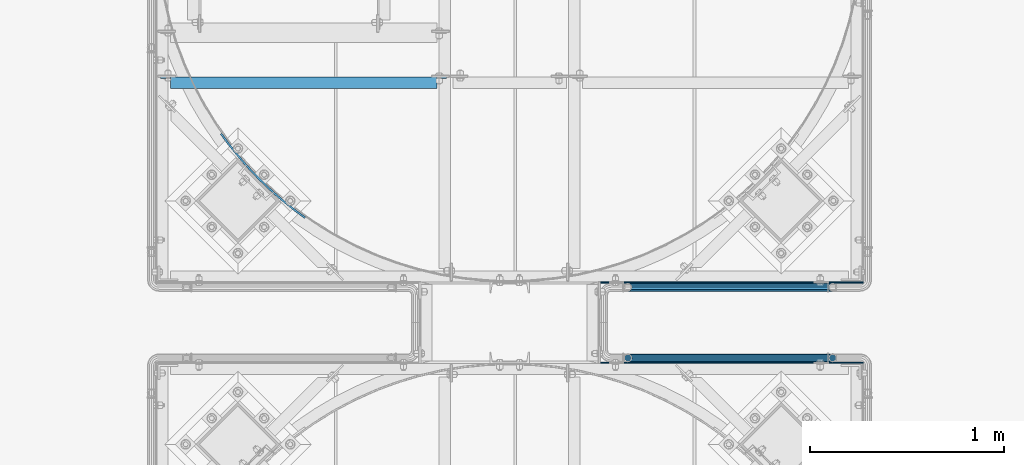
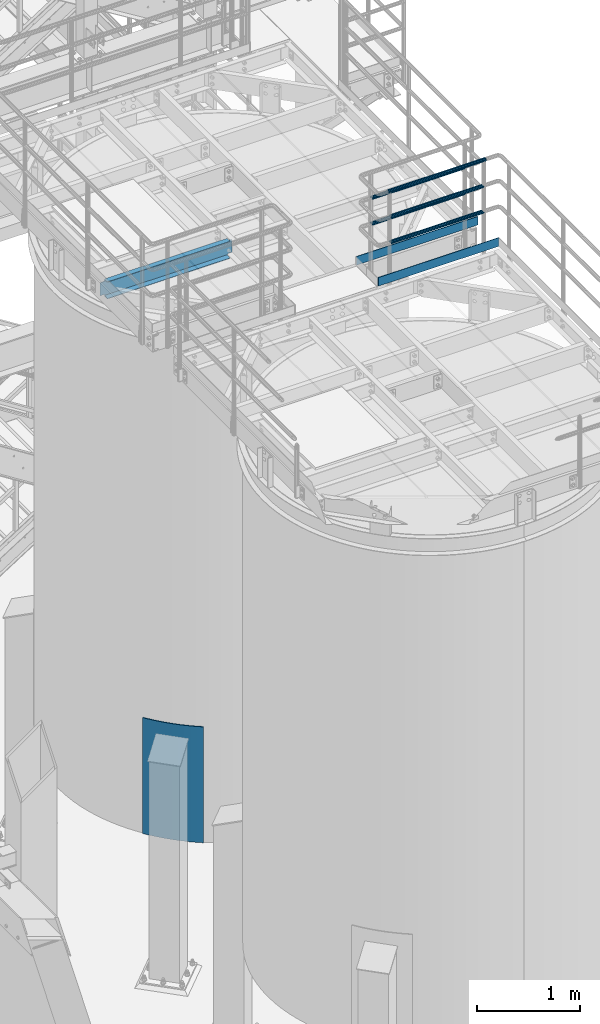
# One storey, part 927 of 1876: 9 beams, 4 elements without a shape of their own.
"""IFC2X3 building model written with IfcOpenShell, lengths in millimetres."""

from ifc_helpers import new_model, si_unit, frame, origin_with_axes, place, context, subcontext, project, spatial, faceted_brep, material, type_object, element, aggregate, save


model = new_model("IFC2X3")

# Units and contexts
model_context = context("Model", 3, precision=1e-05, world=origin_with_axes())
body_context = subcontext(model_context, "Body", "Model", "MODEL_VIEW")
ifc_project = project(units=[si_unit("LENGTHUNIT", "METRE", prefix="MILLI"), si_unit("AREAUNIT", "SQUARE_METRE"), si_unit("VOLUMEUNIT", "CUBIC_METRE"), si_unit("MASSUNIT", "GRAM", prefix="KILO"), si_unit("TIMEUNIT", "SECOND"), si_unit("PLANEANGLEUNIT", "RADIAN"), si_unit("SOLIDANGLEUNIT", "STERADIAN"), si_unit("THERMODYNAMICTEMPERATUREUNIT", "DEGREE_CELSIUS"), si_unit("LUMINOUSINTENSITYUNIT", "LUMEN")], contexts=[model_context])

# Site, building, storey
site_placement = place(None, origin_with_axes())
site = spatial("IfcSite", under=ifc_project, at=site_placement, CompositionType="ELEMENT")
building_placement = place(site_placement, origin_with_axes())
building = spatial("IfcBuilding", under=site, at=building_placement, Name="Undefined", CompositionType="ELEMENT")
storey_placement = place(building_placement, origin_with_axes())
storey = spatial("IfcBuildingStorey", under=building, at=storey_placement, Name="Undefined", CompositionType="ELEMENT", Elevation=0.0)

# Assembly, beams
assembly_1_placement = place(storey_placement, origin_with_axes())
assembly_1 = element("IfcElementAssembly", 1, at=assembly_1_placement, inside=storey, Name="HANDRAIL", AssemblyPlace="NOTDEFINED", PredefinedType="RIGID_FRAME")
ifc_material_1 = material()
beam_type_1 = type_object("IfcBeamType", Name="PIPE1-1/4STD", PredefinedType="NOTDEFINED")
beam_1_placement = place(assembly_1_placement, frame((6845.30143150122, -11745.4324531237, 8480.425), z_axis=(0.0, 0.0, 1.0), x_axis=(-1.0, 0.0, 0.0)))
beam_1 = element("IfcBeam", 2, at=beam_1_placement, type_object=beam_type_1, material=ifc_material_1, Name="RAIL", ObjectType="PIPE1-1/4STD", context=body_context, shape_type="Brep", body=[
    faceted_brep([(1035.84245243742, -10.5409999999993, 18.2575475625836), (1035.84245243742, -10.5409999999993, 13.3999612267253), (1035.36603877327, -8.76300000000083, 15.1779612267255), (1033.018, 0.0, 17.5259999999998), (1033.018, 0.0, 21.0820000000003), (1035.36603877327, 8.76300000000083, 15.1779612267255), (1035.84245243742, 10.5409999999993, 13.3999612267253), (1035.84245243742, 10.5409999999993, 18.2575475625836), (1054.1, 21.0820000000003, 0.0), (1043.559, 18.2575475625836, 10.5409999999993), (1043.559, 18.2575475625836, -10.5409999999993), (1040.47941366414, 15.1779612267255, 8.76300000000083), (1042.82745243742, 17.5259999999998, 0.0), (1040.47941366414, 15.1779612267255, -8.76300000000083), (1035.84245243742, 10.5409999999993, -13.3999612267253), (1035.84245243742, 10.5409999999993, -18.2575475625836), (1035.36603877327, 8.76300000000083, -15.1779612267255), (1033.018, 0.0, -17.5259999999998), (1033.018, 0.0, -21.0820000000003), (1035.84245243742, -10.5409999999993, -13.3999612267253), (1035.84245243742, -10.5409999999993, -18.2575475625836), (1035.36603877327, -8.76300000000083, -15.1779612267255), (1054.1, -21.0820000000003, 0.0), (1043.559, -18.2575475625836, -10.5409999999993), (1043.559, -18.2575475625836, 10.5409999999993), (1040.47941366414, -15.1779612267255, -8.76300000000083), (1042.82745243742, -17.5259999999998, 0.0), (1040.47941366414, -15.1779612267255, 8.76300000000083), (10.5409999957128, -18.2575475672238, -10.5409999999993), (18.2575475625817, -10.5410000000011, -18.2575475625836), (9.09494701772928e-13, 21.0820000000003, 0.0), (10.5409999957128, 18.2575475579433, -10.5409999999993), (10.5409999999983, 18.2575475625836, 10.5410000000011), (18.2575475625817, 10.5409999999993, 18.2575475625836), (21.0819999999985, 1.81898940354586e-12, 21.0820000000003), (18.2575475625817, 10.5409999999993, -18.2575475625836), (21.0819999999985, 0.0, -21.0819999999985), (21.0819999999985, 0.0, -17.5259999999998), (18.2575475625817, -10.5409999999974, -13.3999612267271), (18.7339612267233, -8.76300000000083, -15.1779612267255), (18.7339612267251, 8.76299999999901, -15.1779612267255), (18.2575475625817, 10.5410000000011, -13.3999612267235), (13.6205863358573, 15.1779612267255, -8.76299999999901), (11.2725475625839, 17.5259999999998, 0.0), (13.6205863358573, 15.1779612267255, 8.76300000000083), (18.2575475625817, 10.5410000000011, 13.3999612267253), (18.7339612267251, 8.76299999999901, 15.1779612267273), (21.0819999999985, 1.81898940354586e-12, 17.5259999999998), (18.7339612267233, -8.76300000000083, 15.1779612267273), (18.2575475625817, -10.5409999999974, 13.3999612267289), (18.2575475625817, -10.5410000000011, 18.2575475625836), (10.5409999999983, -18.2575475625836, 10.5410000000011), (9.09494701772928e-13, -21.0820000000003, 0.0), (13.6205863358537, -15.1779612267255, 8.76300000000083), (11.2725475625793, -17.5259999999998, 0.0), (13.6205863358537, -15.1779612267255, -8.76299999999901)], [[[0, 1, 2, 3, 4]], [[4, 3, 5, 6, 7]], [[8, 9, 10]], [[7, 6, 11, 12, 13, 14, 15, 10, 9]], [[16, 17, 18, 15, 14]], [[19, 20, 18, 17, 21]], [[22, 23, 24]], [[24, 23, 20, 19, 25, 26, 27, 1, 0]], [[28, 29, 20, 23]], [[30, 31, 32]], [[33, 34, 4, 7]], [[32, 33, 7, 9]], [[30, 32, 9, 8]], [[31, 30, 8, 10]], [[35, 31, 10, 15]], [[36, 35, 15, 18]], [[29, 36, 18, 20]], [[37, 36, 29, 38, 39]], [[40, 41, 35, 36, 37]], [[32, 31, 35, 41, 42, 43, 44, 45, 33]], [[33, 45, 46, 47, 34]], [[34, 47, 48, 49, 50]], [[34, 50, 0, 4]], [[50, 51, 24, 0]], [[51, 52, 22, 24]], [[52, 28, 23, 22]], [[51, 28, 52]], [[50, 49, 53, 54, 55, 38, 29, 28, 51]], [[55, 54, 26, 25]], [[21, 39, 38, 55, 25, 19]], [[37, 39, 21, 17]], [[40, 37, 17, 16]], [[42, 41, 40, 16, 14, 13]], [[43, 42, 13, 12]], [[44, 43, 12, 11]], [[5, 46, 45, 44, 11, 6]], [[47, 46, 5, 3]], [[48, 47, 3, 2]], [[53, 49, 48, 2, 1, 27]], [[54, 53, 27, 26]]]),
])
beam_2_placement = place(assembly_1_placement, frame((5791.20143150122, -11745.4324531238, 8785.225), z_axis=(0.0, 0.0, -1.0), x_axis=(1.0, 0.0, 0.0)))
beam_2 = element("IfcBeam", 3, at=beam_2_placement, type_object=beam_type_1, material=ifc_material_1, Name="RAIL", ObjectType="PIPE1-1/4STD", context=body_context, shape_type="Brep", body=[
    faceted_brep([(9.09494701772928e-13, 21.0820000000003, 0.0), (10.5409999957128, 18.2575475579433, -10.5409999999993), (10.5409999999983, 18.2575475625836, 10.5410000000011), (10.5409999999983, -18.2575475625836, 10.5410000000011), (10.5409999957128, -18.2575475672238, -10.5409999999993), (9.09494701772928e-13, -21.0820000000003, 0.0), (18.2575475625817, -10.5410000000011, 18.2575475625836), (18.2575475625817, -10.5409999999974, 13.3999612267289), (13.6205863358537, -15.1779612267255, 8.76300000000083), (11.2725475625793, -17.5259999999998, 0.0), (13.6205863358537, -15.1779612267255, -8.76299999999901), (18.2575475625817, -10.5409999999974, -13.3999612267271), (18.2575475625817, -10.5410000000011, -18.2575475625836), (21.0819999999985, 0.0, -17.5259999999998), (21.0819999999985, 0.0, -21.0819999999985), (18.7339612267233, -8.76300000000083, -15.1779612267255), (18.7339612267251, 8.76299999999901, -15.1779612267255), (18.2575475625817, 10.5410000000011, -13.3999612267235), (18.2575475625817, 10.5409999999993, -18.2575475625836), (13.6205863358573, 15.1779612267255, -8.76299999999901), (11.2725475625839, 17.5259999999998, 0.0), (13.6205863358573, 15.1779612267255, 8.76300000000083), (18.2575475625817, 10.5410000000011, 13.3999612267253), (18.2575475625817, 10.5409999999993, 18.2575475625836), (18.7339612267251, 8.76299999999901, 15.1779612267273), (21.0819999999985, 1.81898940354586e-12, 17.5259999999998), (21.0819999999985, 1.81898940354586e-12, 21.0820000000003), (18.7339612267233, -8.76300000000083, 15.1779612267273), (1054.1, 21.0820000000003, 0.0), (1043.559, 18.2575475625836, -10.5409999999993), (1035.84245243742, 10.5409999999993, -18.2575475625836), (1054.1, -21.0820000000003, 0.0), (1043.559, -18.2575475625836, -10.5409999999993), (1043.559, -18.2575475625836, 10.5409999999993), (1035.84245243742, -10.5409999999993, 18.2575475625836), (1035.84245243742, -10.5409999999993, -18.2575475625836), (1033.018, 0.0, -21.0820000000003), (1035.36603877327, 8.76300000000083, -15.1779612267255), (1033.018, 0.0, -17.5259999999998), (1035.84245243742, 10.5409999999993, -13.3999612267253), (1035.84245243742, -10.5409999999993, -13.3999612267253), (1035.36603877327, -8.76300000000083, -15.1779612267255), (1040.47941366414, -15.1779612267255, -8.76300000000083), (1042.82745243742, -17.5259999999998, 0.0), (1040.47941366414, -15.1779612267255, 8.76300000000083), (1035.84245243742, -10.5409999999993, 13.3999612267253), (1035.36603877327, -8.76300000000083, 15.1779612267255), (1033.018, 0.0, 17.5259999999998), (1033.018, 0.0, 21.0820000000003), (1035.84245243742, 10.5409999999993, 18.2575475625836), (1043.559, 18.2575475625836, 10.5409999999993), (1035.84245243742, 10.5409999999993, 13.3999612267253), (1040.47941366414, 15.1779612267255, 8.76300000000083), (1042.82745243742, 17.5259999999998, 0.0), (1040.47941366414, 15.1779612267255, -8.76300000000083), (1035.36603877327, 8.76300000000083, 15.1779612267255)], [[[0, 1, 2]], [[3, 4, 5]], [[6, 7, 8, 9, 10, 11, 12, 4, 3]], [[13, 14, 12, 11, 15]], [[16, 17, 18, 14, 13]], [[2, 1, 18, 17, 19, 20, 21, 22, 23]], [[23, 22, 24, 25, 26]], [[26, 25, 27, 7, 6]], [[1, 0, 28, 29]], [[18, 1, 29, 30]], [[31, 32, 33]], [[6, 3, 33, 34]], [[3, 5, 31, 33]], [[5, 4, 32, 31]], [[4, 12, 35, 32]], [[12, 14, 36, 35]], [[14, 18, 30, 36]], [[37, 38, 36, 30, 39]], [[40, 35, 36, 38, 41]], [[33, 32, 35, 40, 42, 43, 44, 45, 34]], [[34, 45, 46, 47, 48]], [[26, 6, 34, 48]], [[2, 23, 49, 50]], [[23, 26, 48, 49]], [[0, 2, 50, 28]], [[28, 50, 29]], [[49, 51, 52, 53, 54, 39, 30, 29, 50]], [[48, 47, 55, 51, 49]], [[25, 24, 55, 47]], [[55, 24, 22, 21, 52, 51]], [[21, 20, 53, 52]], [[20, 19, 54, 53]], [[19, 17, 16, 37, 39, 54]], [[16, 13, 38, 37]], [[13, 15, 41, 38]], [[41, 15, 11, 10, 42, 40]], [[10, 9, 43, 42]], [[9, 8, 44, 43]], [[8, 7, 27, 46, 45, 44]], [[27, 25, 47, 46]]]),
])
beam_3_placement = place(assembly_1_placement, frame((5770.11943150122, -11745.4324531238, 9090.025), z_axis=(0.0, 0.0, -1.0), x_axis=(1.0, 0.0, 0.0)))
beam_3 = element("IfcBeam", 4, at=beam_3_placement, type_object=beam_type_1, material=ifc_material_1, Name="HANDRAIL", ObjectType="PIPE1-1/4STD", context=body_context, shape_type="Brep", body=[
    faceted_brep([(0.0, -17.5259999999998, 0.0), (0.0, -15.1779612267264, 8.76300000000083), (1096.264, -15.1779612267255, 8.76300000000083), (1096.264, -17.5259999999998, 0.0), (0.0, -8.76299999999992, 15.1779612267255), (1096.264, -8.76300000000083, 15.1779612267255), (0.0, 0.0, 17.5259999999998), (1096.264, 0.0, 17.5259999999998), (0.0, 8.76299999999992, 15.1779612267255), (1096.264, 8.76300000000083, 15.1779612267255), (0.0, 15.1779612267264, 8.76300000000083), (1096.264, 15.1779612267255, 8.76300000000083), (0.0, 17.5259999999998, 0.0), (1096.264, 17.5259999999998, 0.0), (0.0, 15.1779612267264, -8.76300000000083), (1096.264, 15.1779612267255, -8.76300000000083), (0.0, 8.76299999999992, -15.1779612267255), (1096.264, 8.76300000000083, -15.1779612267255), (0.0, 0.0, -17.5259999999998), (1096.264, 0.0, -17.5259999999998), (0.0, -8.76299999999992, -15.1779612267255), (1096.264, -8.76300000000083, -15.1779612267255), (0.0, -15.1779612267264, -8.76300000000083), (1096.264, -15.1779612267255, -8.76300000000083), (9.09494701772928e-13, -21.0820000000003, 0.0), (0.0, -18.2575475625836, -10.5409999999993), (1096.264, -18.2575475625836, -10.5409999999993), (1096.264, -21.0820000000003, 0.0), (0.0, -10.5410000000002, -18.2575475625836), (1096.264, -10.5409999999993, -18.2575475625836), (-4.28826751885936e-09, 0.0, -21.0820000000003), (1096.264, 0.0, -21.0820000000003), (0.0, 10.5410000000002, -18.2575475625836), (1096.264, 10.5409999999993, -18.2575475625836), (0.0, 18.2575475625836, -10.5409999999993), (1096.264, 18.2575475625836, -10.5409999999993), (9.09494701772928e-13, 21.0820000000003, 0.0), (1096.264, 21.0820000000003, 0.0), (0.0, 18.2575475625836, 10.5409999999993), (1096.264, 18.2575475625836, 10.5409999999993), (0.0, 10.5410000000002, 18.2575475625836), (1096.264, 10.5409999999993, 18.2575475625836), (0.0, 0.0, 21.0820000000003), (1096.264, 0.0, 21.0820000000003), (0.0, -10.5410000000002, 18.2575475625836), (1096.264, -10.5409999999993, 18.2575475625836), (0.0, -18.2575475625836, 10.5409999999993), (1096.264, -18.2575475625836, 10.5409999999993)], [[[0, 1, 2, 3]], [[1, 4, 5, 2]], [[4, 6, 7, 5]], [[6, 8, 9, 7]], [[8, 10, 11, 9]], [[10, 12, 13, 11]], [[12, 14, 15, 13]], [[14, 16, 17, 15]], [[16, 18, 19, 17]], [[18, 20, 21, 19]], [[20, 22, 23, 21]], [[22, 0, 3, 23]], [[24, 25, 26, 27]], [[25, 28, 29, 26]], [[28, 30, 31, 29]], [[30, 32, 33, 31]], [[32, 34, 35, 33]], [[34, 36, 37, 35]], [[36, 38, 39, 37]], [[38, 40, 41, 39]], [[40, 42, 43, 41]], [[42, 44, 45, 43]], [[44, 46, 47, 45]], [[46, 24, 27, 47]], [[29, 31, 33, 35, 37, 39, 41, 43, 45, 47, 27, 26], [5, 7, 9, 11, 13, 15, 17, 19, 21, 23, 3, 2]], [[46, 44, 42, 40, 38, 36, 34, 32, 30, 28, 25, 24], [22, 20, 18, 16, 14, 12, 10, 8, 6, 4, 1, 0]]]),
])

assembly_2_placement = place(storey_placement, origin_with_axes())
assembly_2 = element("IfcElementAssembly", 5, at=assembly_2_placement, inside=storey, Name="HANDRAIL", AssemblyPlace="NOTDEFINED", PredefinedType="RIGID_FRAME")
beam_4_placement = place(assembly_2_placement, frame((6845.30474593762, -11381.1963554687, 8480.425), z_axis=(0.0, 0.0, 1.0), x_axis=(-1.0, 0.0, 0.0)))
beam_4 = element("IfcBeam", 6, at=beam_4_placement, type_object=beam_type_1, material=ifc_material_1, Name="RAIL", ObjectType="PIPE1-1/4STD", context=body_context, shape_type="Brep", body=[
    faceted_brep([(1035.84245243742, -10.5409999999993, 18.2575475625836), (1035.84245243742, -10.5409999999993, 13.3999612267253), (1035.36603877327, -8.76300000000083, 15.1779612267255), (1033.018, 0.0, 17.5259999999998), (1033.018, 0.0, 21.0820000000003), (1035.36603877327, 8.76300000000083, 15.1779612267255), (1035.84245243742, 10.5409999999993, 13.3999612267253), (1035.84245243742, 10.5409999999993, 18.2575475625836), (1054.1, 21.0820000000003, 0.0), (1043.559, 18.2575475625836, 10.5409999999993), (1043.559, 18.2575475625836, -10.5409999999993), (1040.47941366414, 15.1779612267255, 8.76300000000083), (1042.82745243742, 17.5259999999998, 0.0), (1040.47941366414, 15.1779612267255, -8.76300000000083), (1035.84245243742, 10.5409999999993, -13.3999612267253), (1035.84245243742, 10.5409999999993, -18.2575475625836), (1035.36603877327, 8.76300000000083, -15.1779612267255), (1033.018, 0.0, -17.5259999999998), (1033.018, 0.0, -21.0820000000003), (1035.84245243742, -10.5409999999993, -13.3999612267253), (1035.84245243742, -10.5409999999993, -18.2575475625836), (1035.36603877327, -8.76300000000083, -15.1779612267255), (1054.1, -21.0820000000003, 0.0), (1043.559, -18.2575475625836, -10.5409999999993), (1043.559, -18.2575475625836, 10.5409999999993), (1040.47941366414, -15.1779612267255, -8.76300000000083), (1042.82745243742, -17.5259999999998, 0.0), (1040.47941366414, -15.1779612267255, 8.76300000000083), (10.5409999957128, -18.2575475672238, -10.5409999999993), (18.2575475625817, -10.5410000000011, -18.2575475625836), (9.09494701772928e-13, 21.0820000000003, 0.0), (10.5409999957128, 18.2575475579433, -10.5409999999993), (10.5409999999983, 18.2575475625836, 10.5410000000011), (18.2575475625817, 10.5409999999993, 18.2575475625836), (21.0819999999985, 1.81898940354586e-12, 21.0820000000003), (18.2575475625817, 10.5409999999993, -18.2575475625836), (21.0819999999985, 0.0, -21.0819999999985), (21.0819999999985, 0.0, -17.5259999999998), (18.2575475625817, -10.5409999999974, -13.3999612267271), (18.7339612267233, -8.76300000000083, -15.1779612267255), (18.7339612267251, 8.76299999999901, -15.1779612267255), (18.2575475625817, 10.5410000000011, -13.3999612267235), (13.6205863358573, 15.1779612267255, -8.76299999999901), (11.2725475625839, 17.5259999999998, 0.0), (13.6205863358573, 15.1779612267255, 8.76300000000083), (18.2575475625817, 10.5410000000011, 13.3999612267253), (18.7339612267251, 8.76299999999901, 15.1779612267273), (21.0819999999985, 1.81898940354586e-12, 17.5259999999998), (18.7339612267233, -8.76300000000083, 15.1779612267273), (18.2575475625817, -10.5409999999974, 13.3999612267289), (18.2575475625817, -10.5410000000011, 18.2575475625836), (10.5409999999983, -18.2575475625836, 10.5410000000011), (9.09494701772928e-13, -21.0820000000003, 0.0), (13.6205863358537, -15.1779612267255, 8.76300000000083), (11.2725475625793, -17.5259999999998, 0.0), (13.6205863358537, -15.1779612267255, -8.76299999999901)], [[[0, 1, 2, 3, 4]], [[4, 3, 5, 6, 7]], [[8, 9, 10]], [[7, 6, 11, 12, 13, 14, 15, 10, 9]], [[16, 17, 18, 15, 14]], [[19, 20, 18, 17, 21]], [[22, 23, 24]], [[24, 23, 20, 19, 25, 26, 27, 1, 0]], [[28, 29, 20, 23]], [[30, 31, 32]], [[33, 34, 4, 7]], [[32, 33, 7, 9]], [[30, 32, 9, 8]], [[31, 30, 8, 10]], [[35, 31, 10, 15]], [[36, 35, 15, 18]], [[29, 36, 18, 20]], [[37, 36, 29, 38, 39]], [[40, 41, 35, 36, 37]], [[32, 31, 35, 41, 42, 43, 44, 45, 33]], [[33, 45, 46, 47, 34]], [[34, 47, 48, 49, 50]], [[34, 50, 0, 4]], [[50, 51, 24, 0]], [[51, 52, 22, 24]], [[52, 28, 23, 22]], [[51, 28, 52]], [[50, 49, 53, 54, 55, 38, 29, 28, 51]], [[55, 54, 26, 25]], [[21, 39, 38, 55, 25, 19]], [[37, 39, 21, 17]], [[40, 37, 17, 16]], [[42, 41, 40, 16, 14, 13]], [[43, 42, 13, 12]], [[44, 43, 12, 11]], [[5, 46, 45, 44, 11, 6]], [[47, 46, 5, 3]], [[48, 47, 3, 2]], [[53, 49, 48, 2, 1, 27]], [[54, 53, 27, 26]]]),
])
beam_5_placement = place(assembly_2_placement, frame((5791.20474593762, -11381.1963554687, 8785.225), z_axis=(0.0, 0.0, -1.0), x_axis=(1.0, 0.0, 0.0)))
beam_5 = element("IfcBeam", 7, at=beam_5_placement, type_object=beam_type_1, material=ifc_material_1, Name="RAIL", ObjectType="PIPE1-1/4STD", context=body_context, shape_type="Brep", body=[
    faceted_brep([(9.09494701772928e-13, 21.0820000000003, 0.0), (10.5409999957128, 18.2575475579433, -10.5409999999993), (10.5409999999983, 18.2575475625836, 10.5410000000011), (10.5409999999983, -18.2575475625836, 10.5410000000011), (10.5409999957128, -18.2575475672238, -10.5409999999993), (9.09494701772928e-13, -21.0820000000003, 0.0), (18.2575475625817, -10.5410000000011, 18.2575475625836), (18.2575475625817, -10.5409999999974, 13.3999612267289), (13.6205863358537, -15.1779612267255, 8.76300000000083), (11.2725475625793, -17.5259999999998, 0.0), (13.6205863358537, -15.1779612267255, -8.76299999999901), (18.2575475625817, -10.5409999999974, -13.3999612267271), (18.2575475625817, -10.5410000000011, -18.2575475625836), (21.0819999999985, 0.0, -17.5259999999998), (21.0819999999985, 0.0, -21.0819999999985), (18.7339612267233, -8.76300000000083, -15.1779612267255), (18.7339612267251, 8.76299999999901, -15.1779612267255), (18.2575475625817, 10.5410000000011, -13.3999612267235), (18.2575475625817, 10.5409999999993, -18.2575475625836), (13.6205863358573, 15.1779612267255, -8.76299999999901), (11.2725475625839, 17.5259999999998, 0.0), (13.6205863358573, 15.1779612267255, 8.76300000000083), (18.2575475625817, 10.5410000000011, 13.3999612267253), (18.2575475625817, 10.5409999999993, 18.2575475625836), (18.7339612267251, 8.76299999999901, 15.1779612267273), (21.0819999999985, 1.81898940354586e-12, 17.5259999999998), (21.0819999999985, 1.81898940354586e-12, 21.0820000000003), (18.7339612267233, -8.76300000000083, 15.1779612267273), (1054.1, 21.0820000000003, 0.0), (1043.559, 18.2575475625836, -10.5409999999993), (1035.84245243742, 10.5409999999993, -18.2575475625836), (1054.1, -21.0820000000003, 0.0), (1043.559, -18.2575475625836, -10.5409999999993), (1043.559, -18.2575475625836, 10.5409999999993), (1035.84245243742, -10.5409999999993, 18.2575475625836), (1035.84245243742, -10.5409999999993, -18.2575475625836), (1033.018, 0.0, -21.0820000000003), (1035.36603877327, 8.76300000000083, -15.1779612267255), (1033.018, 0.0, -17.5259999999998), (1035.84245243742, 10.5409999999993, -13.3999612267253), (1035.84245243742, -10.5409999999993, -13.3999612267253), (1035.36603877327, -8.76300000000083, -15.1779612267255), (1040.47941366414, -15.1779612267255, -8.76300000000083), (1042.82745243742, -17.5259999999998, 0.0), (1040.47941366414, -15.1779612267255, 8.76300000000083), (1035.84245243742, -10.5409999999993, 13.3999612267253), (1035.36603877327, -8.76300000000083, 15.1779612267255), (1033.018, 0.0, 17.5259999999998), (1033.018, 0.0, 21.0820000000003), (1035.84245243742, 10.5409999999993, 18.2575475625836), (1043.559, 18.2575475625836, 10.5409999999993), (1035.84245243742, 10.5409999999993, 13.3999612267253), (1040.47941366414, 15.1779612267255, 8.76300000000083), (1042.82745243742, 17.5259999999998, 0.0), (1040.47941366414, 15.1779612267255, -8.76300000000083), (1035.36603877327, 8.76300000000083, 15.1779612267255)], [[[0, 1, 2]], [[3, 4, 5]], [[6, 7, 8, 9, 10, 11, 12, 4, 3]], [[13, 14, 12, 11, 15]], [[16, 17, 18, 14, 13]], [[2, 1, 18, 17, 19, 20, 21, 22, 23]], [[23, 22, 24, 25, 26]], [[26, 25, 27, 7, 6]], [[1, 0, 28, 29]], [[18, 1, 29, 30]], [[31, 32, 33]], [[6, 3, 33, 34]], [[3, 5, 31, 33]], [[5, 4, 32, 31]], [[4, 12, 35, 32]], [[12, 14, 36, 35]], [[14, 18, 30, 36]], [[37, 38, 36, 30, 39]], [[40, 35, 36, 38, 41]], [[33, 32, 35, 40, 42, 43, 44, 45, 34]], [[34, 45, 46, 47, 48]], [[26, 6, 34, 48]], [[2, 23, 49, 50]], [[23, 26, 48, 49]], [[0, 2, 50, 28]], [[28, 50, 29]], [[49, 51, 52, 53, 54, 39, 30, 29, 50]], [[48, 47, 55, 51, 49]], [[25, 24, 55, 47]], [[55, 24, 22, 21, 52, 51]], [[21, 20, 53, 52]], [[20, 19, 54, 53]], [[19, 17, 16, 37, 39, 54]], [[16, 13, 38, 37]], [[13, 15, 41, 38]], [[41, 15, 11, 10, 42, 40]], [[10, 9, 43, 42]], [[9, 8, 44, 43]], [[8, 7, 27, 46, 45, 44]], [[27, 25, 47, 46]]]),
])
ifc_material_2 = material(Name="STEEL/A36")
beam_type_2 = type_object("IfcBeamType", PredefinedType="NOTDEFINED")
beam_6_placement = place(assembly_2_placement, frame((5645.15143150122, -11356.9398085925, 8080.375), z_axis=(0.0, 0.0, 1.0), x_axis=(1.0, 0.0, 0.0)))
beam_6 = element("IfcBeam", 8, at=beam_6_placement, type_object=beam_type_2, material=ifc_material_2, Name="PLATE", context=body_context, shape_type="Brep", body=[
    faceted_brep([(6.35000000000036, 3.17499999999927, -50.8000000000002), (0.0, -3.17500000000018, -50.8000000000002), (0.0, -3.17500000000018, 50.8000000000002), (6.35000000000036, 3.17499999999927, 50.8000000000002), (1358.90088293519, 3.17499999999927, 50.8000000000002), (1358.90088293519, 3.17499999999927, -50.8000000000002), (1358.90088293519, -3.17499999999927, 50.8000000000002), (1358.90088293519, -3.17499999999927, -50.8000000000002)], [[[0, 1, 2, 3]], [[4, 5, 0, 3]], [[6, 4, 3, 2]], [[2, 1, 7, 6]], [[5, 7, 1, 0]], [[6, 7, 5, 4]]]),
])
aggregate(assembly_2, [beam_6, beam_4, beam_5])

# Beam
beam_7_placement = place(assembly_1_placement, frame((5645.15143150122, -11769.6894531238, 8080.375), z_axis=(0.0, 0.0, 1.0), x_axis=(1.0, 0.0, 0.0)))
beam_7 = element("IfcBeam", 9, at=beam_7_placement, type_object=beam_type_2, material=ifc_material_2, Name="PLATE", context=body_context, shape_type="Brep", body=[
    faceted_brep([(0.0, 3.17500000000018, -50.8000000000002), (6.35000000000036, -3.17499999999927, -50.8000000000002), (6.35000000000036, -3.17499999999927, 50.8000000000002), (0.0, 3.17500000000018, 50.8000000000002), (1358.89713699757, 3.17499999999927, 50.8000000000002), (1358.89713699757, 3.17499999999927, -50.8000000000002), (1358.89713699757, -3.17499999999927, 50.8000000000002), (1358.89713699757, -3.17499999999927, -50.8000000000002)], [[[0, 1, 2, 3]], [[0, 3, 4, 5]], [[6, 4, 3, 2]], [[7, 6, 2, 1]], [[5, 7, 1, 0]], [[6, 7, 5, 4]]]),
])

aggregate(assembly_1, [beam_7, beam_1, beam_2, beam_3])

# Assembly, beam
assembly_3_placement = place(storey_placement, origin_with_axes())
assembly_3 = element("IfcElementAssembly", 10, at=assembly_3_placement, inside=storey, Name="BEAM", AssemblyPlace="NOTDEFINED", PredefinedType="RIGID_FRAME")
beam_type_3 = type_object("IfcBeamType", Name="C8X11.5", PredefinedType="NOTDEFINED")
beam_8_placement = place(assembly_3_placement, frame((3365.50333884985, -10328.2393554687, 7896.225), z_axis=(0.0, 0.0, 1.0), x_axis=(1.0, 0.0, 0.0)))
beam_8 = element("IfcBeam", 11, at=beam_8_placement, type_object=beam_type_3, material=ifc_material_2, Name="BEAM", ObjectType="C8X11.5", context=body_context, shape_type="Brep", body=[
    faceted_brep([(1441.45, -28.5750000000007, -96.8355949999996), (1441.45, -28.5750000000007, -101.6), (1441.45, 28.5750000000007, -101.6), (1441.45, 28.5750000000007, -88.899999809264), (1441.45, 19.0576241940926, -88.899999809264), (1441.55496303464, 22.2250000000004, -88.3723149999996), (1442.41672992259, 28.5750000000007, -84.0399202912186), (1442.41672992259, 22.2250000000004, -84.0399202912186), (1445.16974382306, 28.5750000000007, -79.9197438230649), (1445.16974382306, 22.2250000000004, -79.9197438230649), (1449.28992029122, 28.5750000000007, -77.1667299225865), (1449.28992029122, 22.2250000000004, -77.1667299225865), (1454.14999980926, 28.5750000000007, -76.1999999999989), (1454.14999980926, 22.2250000000004, -76.1999999999989), (1492.25, 22.2250000000004, -76.1999999999989), (1492.25, 28.5750000000007, -76.1999999999989), (69.8500000000013, 28.5750000000007, 101.6), (69.8500000000013, -28.5750000000007, 101.6), (1441.45, -28.5750000000007, 101.6), (1441.45, 28.5750000000007, 101.6), (69.8500000000013, 19.0576241940817, -88.8999998092659), (69.8500000000013, 28.5750000000007, -88.8999998092659), (69.8500000000013, 28.5750000000007, -101.6), (69.8500000000013, -28.5750000000007, -101.6), (69.8500000000013, -28.5750000000007, -96.8355949999996), (69.7450369653598, 22.2250000000004, -88.3723149999996), (68.8832700774137, 22.2250000000004, -84.0399202912204), (68.8832700774137, 28.5750000000007, -84.0399202912204), (66.1302561769353, 22.2250000000004, -79.9197438230667), (66.1302561769353, 28.5750000000007, -79.9197438230667), (62.0100797087816, 22.2250000000004, -77.1667299225883), (62.0100797087816, 28.5750000000007, -77.1667299225883), (57.1500001907361, 22.2250000000004, -76.2000000000007), (57.1500001907361, 28.5750000000007, -76.2000000000007), (19.0499999999993, 22.2250000000004, -76.2000000000007), (19.0499999999993, 28.5750000000007, -76.2000000000007), (19.0499999999993, 22.2250000000004, 76.1999999999989), (19.0499999999993, 28.5750000000007, 76.1999999999989), (57.1500001907361, 22.2250000000004, 76.1999999999989), (57.1500001907361, 28.5750000000007, 76.1999999999989), (62.0100797087816, 22.2250000000004, 77.1667299225865), (62.0100797087816, 28.5750000000007, 77.1667299225865), (66.1302561769353, 22.2250000000004, 79.9197438230649), (66.1302561769353, 28.5750000000007, 79.9197438230649), (68.8832700774137, 22.2250000000004, 84.0399202912186), (68.8832700774137, 28.5750000000007, 84.0399202912186), (69.8500000000013, 19.0576241940926, 88.899999809264), (69.8500000000013, 28.5750000000007, 88.899999809264), (69.7450369653607, 22.2250000000004, 88.3723149999996), (69.8500000000013, -28.5750000000007, 96.8355949999996), (1441.45, -28.5750000000007, 96.8355949999996), (1441.45, 19.0576241940817, 88.8999998092659), (1441.45, 28.5750000000007, 88.8999998092659), (1441.55496303464, 22.2250000000004, 88.3723149999996), (1442.41672992259, 22.2250000000004, 84.0399202912204), (1442.41672992259, 28.5750000000007, 84.0399202912204), (1445.16974382306, 22.2250000000004, 79.9197438230667), (1445.16974382306, 28.5750000000007, 79.9197438230667), (1449.28992029122, 22.2250000000004, 77.1667299225883), (1449.28992029122, 28.5750000000007, 77.1667299225883), (1454.14999980926, 22.2250000000004, 76.2000000000007), (1454.14999980926, 28.5750000000007, 76.2000000000007), (1492.25, 22.2250000000004, 76.2000000000007), (1492.25, 28.5750000000007, 76.2000000000007)], [[[0, 1, 2, 3, 4]], [[5, 4, 3, 6, 7]], [[7, 6, 8, 9]], [[9, 8, 10, 11]], [[11, 10, 12, 13]], [[14, 13, 12, 15]], [[16, 17, 18, 19]], [[20, 21, 22, 23, 24]], [[25, 26, 27, 21, 20]], [[28, 29, 27, 26]], [[30, 31, 29, 28]], [[32, 33, 31, 30]], [[34, 35, 33, 32]], [[36, 37, 35, 34]], [[38, 39, 37, 36]], [[40, 41, 39, 38]], [[42, 43, 41, 40]], [[44, 45, 43, 42]], [[46, 47, 45, 44, 48]], [[17, 16, 47, 46, 49]], [[17, 49, 50, 18]], [[18, 50, 51, 52, 19]], [[49, 46, 48, 53, 51, 50]], [[54, 55, 52, 51, 53]], [[56, 57, 55, 54]], [[58, 59, 57, 56]], [[60, 61, 59, 58]], [[62, 63, 61, 60]], [[63, 62, 14, 15]], [[10, 8, 6, 3, 2, 22, 21, 27, 29, 31, 33, 35, 37, 39, 41, 43, 45, 47, 16, 19, 52, 55, 57, 59, 61, 63, 15, 12]], [[23, 22, 2, 1]], [[24, 23, 1, 0]], [[25, 20, 24, 0, 4, 5]], [[62, 60, 58, 56, 54, 53, 48, 44, 42, 40, 38, 36, 34, 32, 30, 28, 26, 25, 5, 7, 9, 11, 13, 14]]]),
])
aggregate(assembly_3, [beam_8])

assembly_4_placement = place(storey_placement, origin_with_axes())
assembly_4 = element("IfcElementAssembly", 12, at=assembly_4_placement, inside=storey, Name="COLUMN", AssemblyPlace="NOTDEFINED", PredefinedType="RIGID_FRAME")
beam_type_4 = type_object("IfcBeamType", PredefinedType="NOTDEFINED")
beam_9_placement = place(assembly_4_placement, frame((4128.41379378241, -11023.0721979111, 2209.8), z_axis=(0.0, 0.0, 1.0), x_axis=(-0.707106781186548, 0.707106781186547, 0.0)))
beam_9 = element("IfcBeam", 13, at=beam_9_placement, type_object=beam_type_4, material=ifc_material_2, Name="PLATE", context=body_context, shape_type="Brep", body=[
    faceted_brep([(-0.79930179960138, 4.6949465261232, -685.8), (-0.79930179960138, 4.6949465261232, 685.8), (60.0611937621743, 14.0031633272019, 685.8), (60.0611937621743, 14.0031633272019, -685.8), (0.79930179960138, -4.6949465261232, 685.8), (0.79930179960138, -4.6949465261232, -685.8), (61.3422639062264, 4.56470559905301, -685.8), (61.3422639062264, 4.56470559905301, 685.8), (121.200950016122, 21.2538891700888, 685.8), (121.200950016122, 21.2538891700888, -685.8), (122.163029690721, 11.7776015161735, -685.8), (122.163029690721, 11.7776015161735, 685.8), (182.550430177147, 26.4388775030229, 685.8), (182.550430177147, 26.4388775030229, -685.8), (183.192425169107, 16.9355376990206, -685.8), (183.192425169107, 16.9355376990206, 685.8), (244.039858932445, 29.5522312233416, 685.8), (244.039858932445, 29.5522312233416, -685.8), (244.361039074185, 20.0326478124689, -685.8), (244.361039074185, 20.0326478124689, 685.8), (305.599301799859, 30.5904093845011, 685.8), (305.599301799859, 30.5904093845011, -685.8), (305.599301799861, 21.0654093844987, -685.8), (305.599301799861, 21.0654093844987, 685.8), (367.158744667275, 29.5522312233416, 685.8), (367.158744667275, 29.5522312233416, -685.8), (366.837564525536, 20.0326478124671, -685.8), (366.837564525536, 20.0326478124671, 685.8), (428.648173422573, 26.4388775030238, 685.8), (428.648173422573, 26.4388775030238, -685.8), (428.006178430616, 16.9355376990216, -685.8), (428.006178430616, 16.9355376990216, 685.8), (489.997653583598, 21.2538891700897, 685.8), (489.997653583598, 21.2538891700897, -685.8), (489.035573908999, 11.7776015161735, -685.8), (489.035573908999, 11.7776015161735, 685.8), (551.137409837545, 14.0031633272019, 685.8), (551.137409837545, 14.0031633272019, -685.8), (549.856339693495, 4.56470559905301, -685.8), (549.856339693495, 4.56470559905301, 685.8), (611.997905399321, 4.6949465261232, 685.8), (611.997905399321, 4.6949465261232, -685.8), (610.399301800118, -4.69494652612411, 685.8), (610.399301800118, -4.69494652612411, -685.8)], [[[0, 1, 2, 3]], [[4, 5, 6, 7]], [[5, 4, 1, 0]], [[3, 2, 8, 9]], [[7, 6, 10, 11]], [[9, 8, 12, 13]], [[11, 10, 14, 15]], [[13, 12, 16, 17]], [[15, 14, 18, 19]], [[17, 16, 20, 21]], [[19, 18, 22, 23]], [[21, 20, 24, 25]], [[23, 22, 26, 27]], [[25, 24, 28, 29]], [[27, 26, 30, 31]], [[29, 28, 32, 33]], [[31, 30, 34, 35]], [[33, 32, 36, 37]], [[35, 34, 38, 39]], [[37, 36, 40, 41]], [[36, 32, 28, 24, 20, 16, 12, 8, 2, 1, 4, 7, 11, 15, 19, 23, 27, 31, 35, 39, 42, 40]], [[39, 38, 43, 42]], [[38, 34, 30, 26, 22, 18, 14, 10, 6, 5, 0, 3, 9, 13, 17, 21, 25, 29, 33, 37, 41, 43]], [[42, 43, 41, 40]]]),
])
aggregate(assembly_4, [beam_9])

save(model, "model.ifc")
